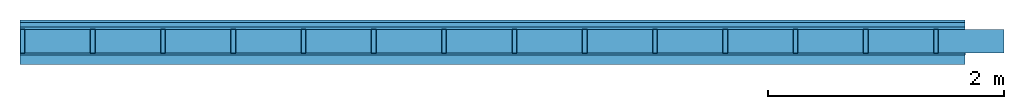
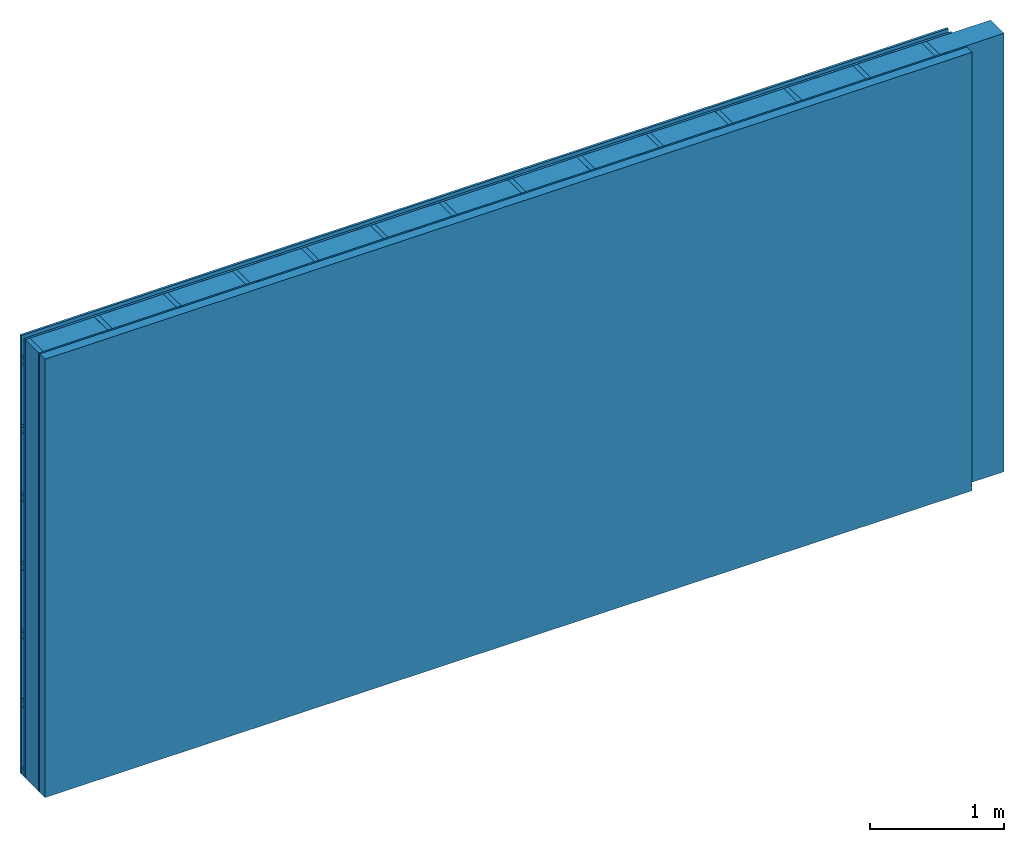
# One storey: 4 plates, 3 members, 1 element without a shape of its own.
"""IFC4 building model written with IfcOpenShell, lengths in metres."""

from ifc_helpers import new_model, si_unit, derived_unit, direction, frame, frame_2d, origin, origin_with_axes, place, context, project, spatial, rectangle, extrude, material, layer, layer_set, type_object, element, aggregate, save


model = new_model("IFC4")

# Units and contexts
plan_context = context("Plan", 3, precision=1e-05, world=origin(), true_north=direction((0.0, 1.0)))
model_context = context("Model", 3, precision=1e-05, world=origin(), true_north=direction((0.0, 1.0)))
ifc_project = project(units=[si_unit("LENGTHUNIT", "METRE"), derived_unit("SOUNDPRESSUREUNIT", [(si_unit("PRESSUREUNIT", "PASCAL", prefix="MICRO"), 0)]), si_unit("ENERGYUNIT", "JOULE", prefix="MEGA"), si_unit("MASSUNIT", "GRAM", prefix="KILO"), derived_unit("THERMALTRANSMITTANCEUNIT", [(si_unit("POWERUNIT", "WATT"), 1), (si_unit("AREAUNIT", "SQUARE_METRE"), -1), (si_unit("THERMODYNAMICTEMPERATUREUNIT", "KELVIN"), -1)]), derived_unit("AREADENSITYUNIT", [(si_unit("MASSUNIT", "GRAM", prefix="KILO"), 1), (si_unit("AREAUNIT", "SQUARE_METRE"), -1)]), derived_unit("USERDEFINED", [(si_unit("ENERGYUNIT", "JOULE", prefix="MEGA"), 1), (si_unit("AREAUNIT", "SQUARE_METRE"), -1)])], contexts=[plan_context, model_context])

# Site, building, storey
site = spatial("IfcSite", under=ifc_project)
building_placement = place(None, origin())
building = spatial("IfcBuilding", under=site, at=building_placement)
storey_placement = place(building_placement, origin())
storey = spatial("IfcBuildingStorey", under=building, at=storey_placement)

# Wall, members, plates
ifc_material_1 = material(Name="Wood cladding horizontal, closed")
ifc_layer_1 = layer(ifc_material_1, 0.02, Name="Cover 1st layer")
ifc_layer_2 = layer(None, 0.04, Name="Battens / profiles (ventilation)")
ifc_material_2 = material(Category="10.009")
ifc_layer_3 = layer(ifc_material_2, 0.02, Name="outside 1st layer")
ifc_material_3 = material(Name="of the art")
ifc_layer_4 = layer(ifc_material_3, 0.0, Name="Bond")
ifc_layer_5 = layer(None, 0.2, Name="Support")
ifc_layer_6 = layer(ifc_material_3, 0.0, Name="Bond")
ifc_material_4 = material(Name="OSB panel", Category="07.013")
ifc_layer_7 = layer(ifc_material_4, 0.015, Name="1st layer")
ifc_material_5 = material(Name="Solid timber panel")
ifc_layer_8 = layer(ifc_material_5, 0.08, Name="Covering 1st layer")
ifc_layer_set = layer_set([ifc_layer_1, ifc_layer_2, ifc_layer_3, ifc_layer_4, ifc_layer_5, ifc_layer_6, ifc_layer_7, ifc_layer_8])
wall_type = type_object("IfcWallType", Name="D0955", PredefinedType="NOTDEFINED", material=ifc_layer_set)
wall_placement = place(None, frame((0.0, 0.0, 0.0), z_axis=(0.0, -1.0, 0.0), x_axis=(1.0, 0.0, 0.0)))
wall = element("IfcWall", 1, at=wall_placement, inside=storey, type_object=wall_type, material=ifc_layer_set, Name="Wall #1")
ifc_material_6 = material()
member_1_placement = place(wall_placement, origin())
member_1 = element("IfcMember", 2, at=member_1_placement, material=ifc_material_6, Name="Battens / profiles (ventilation)", context=plan_context, shape_type="SweptSolid", body=[
    extrude(rectangle(XDim=0.06, YDim=0.04, at=frame_2d((0.03, 0.02), x_axis=(1.0, 0.0))), frame((0.0, 0.0, 0.02), z_axis=(1.0, 0.0, 0.0), x_axis=(0.0, 1.0, 0.0)), (0.0, 0.0, 1.0), 8.0),
    extrude(rectangle(XDim=0.06, YDim=0.04, at=frame_2d((0.03, 0.02), x_axis=(1.0, 0.0))), frame((0.0, 0.625, 0.02), z_axis=(1.0, 0.0, 0.0), x_axis=(0.0, 1.0, 0.0)), (0.0, 0.0, 1.0), 8.0),
    extrude(rectangle(XDim=0.06, YDim=0.04, at=frame_2d((0.03, 0.02), x_axis=(1.0, 0.0))), frame((0.0, 1.25, 0.02), z_axis=(1.0, 0.0, 0.0), x_axis=(0.0, 1.0, 0.0)), (0.0, 0.0, 1.0), 8.0),
    extrude(rectangle(XDim=0.06, YDim=0.04, at=frame_2d((0.03, 0.02), x_axis=(1.0, 0.0))), frame((0.0, 1.875, 0.02), z_axis=(1.0, 0.0, 0.0), x_axis=(0.0, 1.0, 0.0)), (0.0, 0.0, 1.0), 8.0),
    extrude(rectangle(XDim=0.06, YDim=0.04, at=frame_2d((0.03, 0.02), x_axis=(1.0, 0.0))), frame((0.0, 2.5, 0.02), z_axis=(1.0, 0.0, 0.0), x_axis=(0.0, 1.0, 0.0)), (0.0, 0.0, 1.0), 8.0),
    extrude(rectangle(XDim=0.06, YDim=0.04, at=frame_2d((0.03, 0.02), x_axis=(1.0, 0.0))), frame((0.0, 3.125, 0.02), z_axis=(1.0, 0.0, 0.0), x_axis=(0.0, 1.0, 0.0)), (0.0, 0.0, 1.0), 8.0),
    extrude(rectangle(XDim=0.06, YDim=0.04, at=frame_2d((0.03, 0.02), x_axis=(1.0, 0.0))), frame((0.0, 3.75, 0.02), z_axis=(1.0, 0.0, 0.0), x_axis=(0.0, 1.0, 0.0)), (0.0, 0.0, 1.0), 8.0),
])
ifc_material_7 = material()
member_2_placement = place(wall_placement, origin())
member_2 = element("IfcMember", 3, at=member_2_placement, material=ifc_material_7, Name="Support", context=plan_context, shape_type="SweptSolid", body=[
    extrude(rectangle(XDim=0.04, YDim=0.2, at=frame_2d((0.02, 0.1), x_axis=(1.0, 0.0))), frame((0.0, 4.0, 0.08), z_axis=(0.0, -1.0, 0.0), x_axis=(1.0, 0.0, 0.0)), (0.0, 0.0, 1.0), 4.0),
    extrude(rectangle(XDim=0.04, YDim=0.2, at=frame_2d((0.02, 0.1), x_axis=(1.0, 0.0))), frame((0.595, 4.0, 0.08), z_axis=(0.0, -1.0, 0.0), x_axis=(1.0, 0.0, 0.0)), (0.0, 0.0, 1.0), 4.0),
    extrude(rectangle(XDim=0.04, YDim=0.2, at=frame_2d((0.02, 0.1), x_axis=(1.0, 0.0))), frame((1.19, 4.0, 0.08), z_axis=(0.0, -1.0, 0.0), x_axis=(1.0, 0.0, 0.0)), (0.0, 0.0, 1.0), 4.0),
    extrude(rectangle(XDim=0.04, YDim=0.2, at=frame_2d((0.02, 0.1), x_axis=(1.0, 0.0))), frame((1.785, 4.0, 0.08), z_axis=(0.0, -1.0, 0.0), x_axis=(1.0, 0.0, 0.0)), (0.0, 0.0, 1.0), 4.0),
    extrude(rectangle(XDim=0.04, YDim=0.2, at=frame_2d((0.02, 0.1), x_axis=(1.0, 0.0))), frame((2.38, 4.0, 0.08), z_axis=(0.0, -1.0, 0.0), x_axis=(1.0, 0.0, 0.0)), (0.0, 0.0, 1.0), 4.0),
    extrude(rectangle(XDim=0.04, YDim=0.2, at=frame_2d((0.02, 0.1), x_axis=(1.0, 0.0))), frame((2.975, 4.0, 0.08), z_axis=(0.0, -1.0, 0.0), x_axis=(1.0, 0.0, 0.0)), (0.0, 0.0, 1.0), 4.0),
    extrude(rectangle(XDim=0.04, YDim=0.2, at=frame_2d((0.02, 0.1), x_axis=(1.0, 0.0))), frame((3.57, 4.0, 0.08), z_axis=(0.0, -1.0, 0.0), x_axis=(1.0, 0.0, 0.0)), (0.0, 0.0, 1.0), 4.0),
    extrude(rectangle(XDim=0.04, YDim=0.2, at=frame_2d((0.02, 0.1), x_axis=(1.0, 0.0))), frame((4.165, 4.0, 0.08), z_axis=(0.0, -1.0, 0.0), x_axis=(1.0, 0.0, 0.0)), (0.0, 0.0, 1.0), 4.0),
    extrude(rectangle(XDim=0.04, YDim=0.2, at=frame_2d((0.02, 0.1), x_axis=(1.0, 0.0))), frame((4.76, 4.0, 0.08), z_axis=(0.0, -1.0, 0.0), x_axis=(1.0, 0.0, 0.0)), (0.0, 0.0, 1.0), 4.0),
    extrude(rectangle(XDim=0.04, YDim=0.2, at=frame_2d((0.02, 0.1), x_axis=(1.0, 0.0))), frame((5.355, 4.0, 0.08), z_axis=(0.0, -1.0, 0.0), x_axis=(1.0, 0.0, 0.0)), (0.0, 0.0, 1.0), 4.0),
    extrude(rectangle(XDim=0.04, YDim=0.2, at=frame_2d((0.02, 0.1), x_axis=(1.0, 0.0))), frame((5.95, 4.0, 0.08), z_axis=(0.0, -1.0, 0.0), x_axis=(1.0, 0.0, 0.0)), (0.0, 0.0, 1.0), 4.0),
    extrude(rectangle(XDim=0.04, YDim=0.2, at=frame_2d((0.02, 0.1), x_axis=(1.0, 0.0))), frame((6.545, 4.0, 0.08), z_axis=(0.0, -1.0, 0.0), x_axis=(1.0, 0.0, 0.0)), (0.0, 0.0, 1.0), 4.0),
    extrude(rectangle(XDim=0.04, YDim=0.2, at=frame_2d((0.02, 0.1), x_axis=(1.0, 0.0))), frame((7.14, 4.0, 0.08), z_axis=(0.0, -1.0, 0.0), x_axis=(1.0, 0.0, 0.0)), (0.0, 0.0, 1.0), 4.0),
    extrude(rectangle(XDim=0.04, YDim=0.2, at=frame_2d((0.02, 0.1), x_axis=(1.0, 0.0))), frame((7.735, 4.0, 0.08), z_axis=(0.0, -1.0, 0.0), x_axis=(1.0, 0.0, 0.0)), (0.0, 0.0, 1.0), 4.0),
])
ifc_material_8 = material()
member_3_placement = place(wall_placement, origin())
member_3 = element("IfcMember", 4, at=member_3_placement, material=ifc_material_8, Name="Cavity", context=plan_context, shape_type="SweptSolid", body=[
    extrude(rectangle(XDim=0.555, YDim=0.2, at=frame_2d((0.2775, 0.1), x_axis=(1.0, 0.0))), frame((0.04, 4.0, 0.08), z_axis=(0.0, -1.0, 0.0), x_axis=(1.0, 0.0, 0.0)), (0.0, 0.0, 1.0), 4.0),
    extrude(rectangle(XDim=0.555, YDim=0.2, at=frame_2d((0.2775, 0.1), x_axis=(1.0, 0.0))), frame((0.635, 4.0, 0.08), z_axis=(0.0, -1.0, 0.0), x_axis=(1.0, 0.0, 0.0)), (0.0, 0.0, 1.0), 4.0),
    extrude(rectangle(XDim=0.555, YDim=0.2, at=frame_2d((0.2775, 0.1), x_axis=(1.0, 0.0))), frame((1.23, 4.0, 0.08), z_axis=(0.0, -1.0, 0.0), x_axis=(1.0, 0.0, 0.0)), (0.0, 0.0, 1.0), 4.0),
    extrude(rectangle(XDim=0.555, YDim=0.2, at=frame_2d((0.2775, 0.1), x_axis=(1.0, 0.0))), frame((1.825, 4.0, 0.08), z_axis=(0.0, -1.0, 0.0), x_axis=(1.0, 0.0, 0.0)), (0.0, 0.0, 1.0), 4.0),
    extrude(rectangle(XDim=0.555, YDim=0.2, at=frame_2d((0.2775, 0.1), x_axis=(1.0, 0.0))), frame((2.42, 4.0, 0.08), z_axis=(0.0, -1.0, 0.0), x_axis=(1.0, 0.0, 0.0)), (0.0, 0.0, 1.0), 4.0),
    extrude(rectangle(XDim=0.555, YDim=0.2, at=frame_2d((0.2775, 0.1), x_axis=(1.0, 0.0))), frame((3.015, 4.0, 0.08), z_axis=(0.0, -1.0, 0.0), x_axis=(1.0, 0.0, 0.0)), (0.0, 0.0, 1.0), 4.0),
    extrude(rectangle(XDim=0.555, YDim=0.2, at=frame_2d((0.2775, 0.1), x_axis=(1.0, 0.0))), frame((3.61, 4.0, 0.08), z_axis=(0.0, -1.0, 0.0), x_axis=(1.0, 0.0, 0.0)), (0.0, 0.0, 1.0), 4.0),
    extrude(rectangle(XDim=0.555, YDim=0.2, at=frame_2d((0.2775, 0.1), x_axis=(1.0, 0.0))), frame((4.205, 4.0, 0.08), z_axis=(0.0, -1.0, 0.0), x_axis=(1.0, 0.0, 0.0)), (0.0, 0.0, 1.0), 4.0),
    extrude(rectangle(XDim=0.555, YDim=0.2, at=frame_2d((0.2775, 0.1), x_axis=(1.0, 0.0))), frame((4.8, 4.0, 0.08), z_axis=(0.0, -1.0, 0.0), x_axis=(1.0, 0.0, 0.0)), (0.0, 0.0, 1.0), 4.0),
    extrude(rectangle(XDim=0.555, YDim=0.2, at=frame_2d((0.2775, 0.1), x_axis=(1.0, 0.0))), frame((5.395, 4.0, 0.08), z_axis=(0.0, -1.0, 0.0), x_axis=(1.0, 0.0, 0.0)), (0.0, 0.0, 1.0), 4.0),
    extrude(rectangle(XDim=0.555, YDim=0.2, at=frame_2d((0.2775, 0.1), x_axis=(1.0, 0.0))), frame((5.99, 4.0, 0.08), z_axis=(0.0, -1.0, 0.0), x_axis=(1.0, 0.0, 0.0)), (0.0, 0.0, 1.0), 4.0),
    extrude(rectangle(XDim=0.555, YDim=0.2, at=frame_2d((0.2775, 0.1), x_axis=(1.0, 0.0))), frame((6.585, 4.0, 0.08), z_axis=(0.0, -1.0, 0.0), x_axis=(1.0, 0.0, 0.0)), (0.0, 0.0, 1.0), 4.0),
    extrude(rectangle(XDim=0.555, YDim=0.2, at=frame_2d((0.2775, 0.1), x_axis=(1.0, 0.0))), frame((7.18, 4.0, 0.08), z_axis=(0.0, -1.0, 0.0), x_axis=(1.0, 0.0, 0.0)), (0.0, 0.0, 1.0), 4.0),
    extrude(rectangle(XDim=0.555, YDim=0.2, at=frame_2d((0.2775, 0.1), x_axis=(1.0, 0.0))), frame((7.775, 4.0, 0.08), z_axis=(0.0, -1.0, 0.0), x_axis=(1.0, 0.0, 0.0)), (0.0, 0.0, 1.0), 4.0),
])
plate_1_placement = place(wall_placement, origin())
plate_1 = element("IfcPlate", 5, at=plate_1_placement, material=ifc_material_1, Name="Cover 1st layer", context=plan_context, shape_type="SweptSolid", body=[
    extrude(rectangle(XDim=8.0, YDim=4.0, at=frame_2d((4.0, 2.0), x_axis=(1.0, 0.0))), origin_with_axes(), (0.0, 0.0, 1.0), 0.02),
])
plate_2_placement = place(wall_placement, origin())
plate_2 = element("IfcPlate", 6, at=plate_2_placement, material=ifc_material_2, Name="outside 1st layer", context=plan_context, shape_type="SweptSolid", body=[
    extrude(rectangle(XDim=8.0, YDim=4.0, at=frame_2d((4.0, 2.0), x_axis=(1.0, 0.0))), frame((0.0, 0.0, 0.06), z_axis=(0.0, 0.0, 1.0), x_axis=(1.0, 0.0, 0.0)), (0.0, 0.0, 1.0), 0.02),
])
plate_3_placement = place(wall_placement, origin())
plate_3 = element("IfcPlate", 7, at=plate_3_placement, material=ifc_material_4, Name="1st layer", context=plan_context, shape_type="SweptSolid", body=[
    extrude(rectangle(XDim=8.0, YDim=4.0, at=frame_2d((4.0, 2.0), x_axis=(1.0, 0.0))), frame((0.0, 0.0, 0.28), z_axis=(0.0, 0.0, 1.0), x_axis=(1.0, 0.0, 0.0)), (0.0, 0.0, 1.0), 0.015),
])
plate_4_placement = place(wall_placement, origin())
plate_4 = element("IfcPlate", 8, at=plate_4_placement, material=ifc_material_5, Name="Covering 1st layer", context=plan_context, shape_type="SweptSolid", body=[
    extrude(rectangle(XDim=8.0, YDim=4.0, at=frame_2d((4.0, 2.0), x_axis=(1.0, 0.0))), frame((0.0, 0.0, 0.295), z_axis=(0.0, 0.0, 1.0), x_axis=(1.0, 0.0, 0.0)), (0.0, 0.0, 1.0), 0.08),
])
aggregate(wall, [plate_1, member_1, plate_2, member_2, member_3, plate_3, plate_4])

save(model, "model.ifc")
